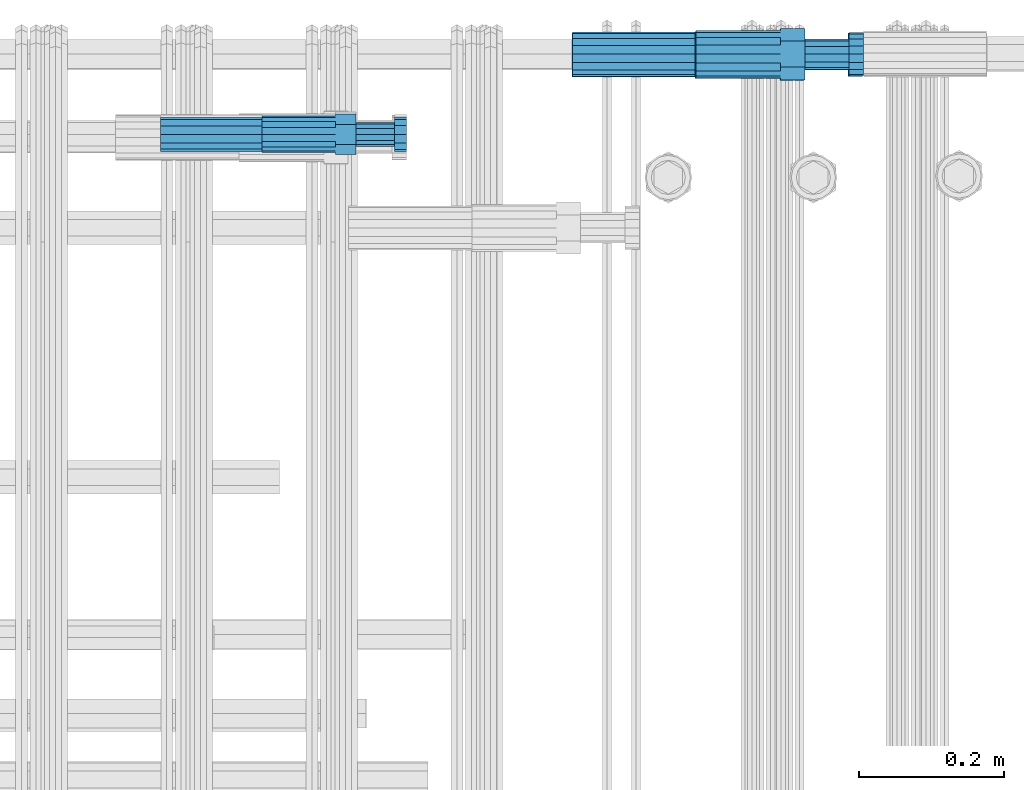
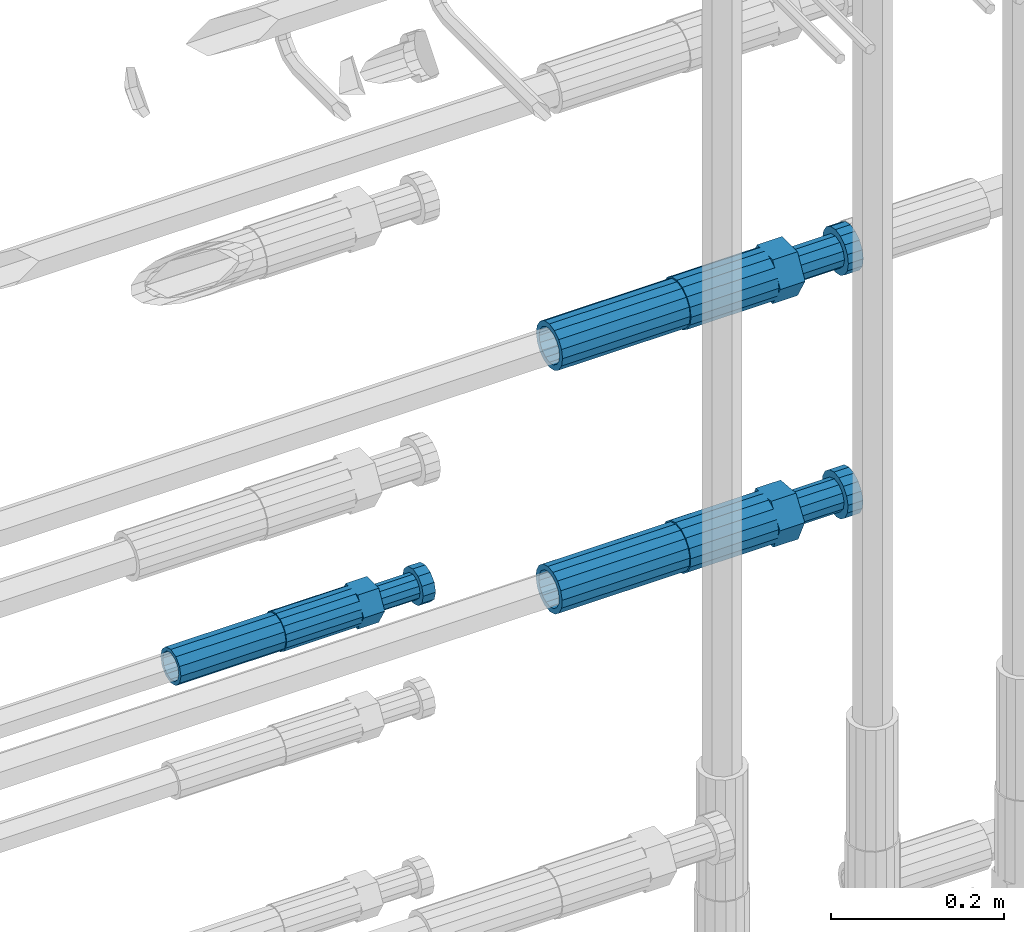
# One storey, part 50 of 177: 6 beams.
"""IFC2X3 building model written with IfcOpenShell, lengths in millimetres."""

from ifc_helpers import new_model, si_unit, frame, origin_with_axes, place, context, subcontext, project, spatial, faceted_brep, material, type_object, element, save


model = new_model("IFC2X3")

# Units and contexts
model_context_1 = context("Model", 3, precision=1e-05, world=origin_with_axes())
model_context_2 = context("Model", 3, precision=1e-05, world=origin_with_axes())
body_context = subcontext(model_context_2, "Body", "Model", "MODEL_VIEW")
ifc_project = project(units=[si_unit("LENGTHUNIT", "METRE", prefix="MILLI"), si_unit("AREAUNIT", "SQUARE_METRE"), si_unit("VOLUMEUNIT", "CUBIC_METRE"), si_unit("MASSUNIT", "GRAM", prefix="KILO"), si_unit("TIMEUNIT", "SECOND"), si_unit("PLANEANGLEUNIT", "RADIAN"), si_unit("SOLIDANGLEUNIT", "STERADIAN"), si_unit("THERMODYNAMICTEMPERATUREUNIT", "DEGREE_CELSIUS"), si_unit("LUMINOUSINTENSITYUNIT", "LUMEN")], contexts=[model_context_1])

# Site, building, storey
site_placement = place(None, origin_with_axes())
site = spatial("IfcSite", under=ifc_project, at=site_placement, CompositionType="ELEMENT")
building_placement = place(site_placement, origin_with_axes())
building = spatial("IfcBuilding", under=site, at=building_placement, Name="Undefined", CompositionType="ELEMENT")
storey_placement = place(building_placement, origin_with_axes())
storey = spatial("IfcBuildingStorey", under=building, at=storey_placement, Name="Undefined", CompositionType="ELEMENT", Elevation=0.0)

# Beams
ifc_material = material(Name="STEEL/S275")
beam_type_1 = type_object("IfcBeamType", PredefinedType="NOTDEFINED")
beam_1_placement = place(storey_placement, frame((2031448.01847313, 6206397.9902193, 19253.0674480899), z_axis=(0.0, -0.0871557420138247, -0.996194698155948), x_axis=(1.0, 0.0, 0.0)))
element("IfcBeam", 1, at=beam_1_placement, inside=storey, type_object=beam_type_1, material=ifc_material, Name="AG40N", context=body_context, shape_type="Brep", body=[
    faceted_brep([(0.0, -23.5000000001164, -9.31322574615479e-10), (0.0, -21.7111690140155, 8.99306066054851), (170.0, -21.7111690140155, 8.99306066054851), (170.0, -23.5, 0.0), (0.0, -16.6170093578839, 16.6170093575493), (170.0, -16.6170093578839, 16.6170093575493), (0.0, -8.99306066057943, 21.7111690137535), (170.0, -8.99306066057943, 21.7111690137535), (0.0, 1.16415321826935e-10, 23.5), (170.0, 0.0, 23.5), (0.0, 8.99306066057943, 21.7111690137535), (170.0, 8.99306066057943, 21.7111690137535), (0.0, 16.6170093578839, 16.6170093575493), (170.0, 16.6170093578839, 16.6170093575493), (0.0, 21.7111690140155, 8.99306066054851), (170.0, 21.7111690140155, 8.99306066054851), (0.0, 23.5000000001164, -9.31322574615479e-10), (170.0, 23.5, 0.0), (0.0, 21.7111690140155, -8.99306066054851), (170.0, 21.7111690140155, -8.99306066054851), (0.0, 16.6170093578839, -16.6170093575493), (170.0, 16.6170093578839, -16.6170093575493), (0.0, 8.99306066057943, -21.7111690137535), (170.0, 8.99306066057943, -21.7111690137535), (0.0, 1.16415321826935e-10, -23.5000000009313), (170.0, 0.0, -23.5), (0.0, -8.99306066057943, -21.7111690137535), (170.0, -8.99306066057943, -21.7111690137535), (0.0, -16.6170093578839, -16.6170093575493), (170.0, -16.6170093578839, -16.6170093575493), (0.0, -21.7111690140155, -8.99306066054851), (170.0, -21.7111690140155, -8.99306066054851), (0.0, -30.5, 0.0), (0.0, -28.1783257415937, -11.6718446873128), (170.0, -28.1783257415937, -11.6718446873128), (170.0, -30.5, 0.0), (0.0, -21.5667568261888, -21.5667568258941), (170.0, -21.5667568261888, -21.5667568258941), (0.0, -11.6718446871346, -28.1783257415518), (170.0, -11.6718446871346, -28.1783257415518), (0.0, 0.0, -30.5), (170.0, 0.0, -30.5), (0.0, 11.6718446871346, -28.1783257415518), (170.0, 11.6718446871346, -28.1783257415518), (0.0, 21.5667568261888, -21.5667568258941), (170.0, 21.5667568261888, -21.5667568258941), (0.0, 28.1783257415937, -11.6718446873128), (170.0, 28.1783257415937, -11.6718446873128), (0.0, 30.5, 0.0), (170.0, 30.5, 0.0), (0.0, 28.1783257415937, 11.6718446873128), (170.0, 28.1783257415937, 11.6718446873128), (0.0, 21.5667568261888, 21.5667568258941), (170.0, 21.5667568261888, 21.5667568258941), (0.0, 11.6718446871346, 28.1783257415518), (170.0, 11.6718446871346, 28.1783257415518), (0.0, 0.0, 30.5), (170.0, 0.0, 30.5), (0.0, -11.6718446871346, 28.1783257415518), (170.0, -11.6718446871346, 28.1783257415518), (0.0, -21.5667568261888, 21.5667568258941), (170.0, -21.5667568261888, 21.5667568258941), (0.0, -28.1783257415937, 11.6718446873128), (170.0, -28.1783257415937, 11.6718446873128)], [[[0, 1, 2, 3]], [[1, 4, 5, 2]], [[4, 6, 7, 5]], [[6, 8, 9, 7]], [[8, 10, 11, 9]], [[10, 12, 13, 11]], [[12, 14, 15, 13]], [[14, 16, 17, 15]], [[16, 18, 19, 17]], [[18, 20, 21, 19]], [[20, 22, 23, 21]], [[22, 24, 25, 23]], [[24, 26, 27, 25]], [[26, 28, 29, 27]], [[28, 30, 31, 29]], [[30, 0, 3, 31]], [[32, 33, 34, 35]], [[33, 36, 37, 34]], [[36, 38, 39, 37]], [[38, 40, 41, 39]], [[40, 42, 43, 41]], [[42, 44, 45, 43]], [[44, 46, 47, 45]], [[46, 48, 49, 47]], [[48, 50, 51, 49]], [[50, 52, 53, 51]], [[52, 54, 55, 53]], [[54, 56, 57, 55]], [[56, 58, 59, 57]], [[58, 60, 61, 59]], [[60, 62, 63, 61]], [[62, 32, 35, 63]], [[37, 39, 41, 43, 45, 47, 49, 51, 53, 55, 57, 59, 61, 63, 35, 34], [5, 7, 9, 11, 13, 15, 17, 19, 21, 23, 25, 27, 29, 31, 3, 2]], [[62, 60, 58, 56, 54, 52, 50, 48, 46, 44, 42, 40, 38, 36, 33, 32], [30, 28, 26, 24, 22, 20, 18, 16, 14, 12, 10, 8, 6, 4, 1, 0]]]),
])
beam_2_placement = place(storey_placement, frame((2031449.01847313, 6206398.98588034, 19594.9868004311), z_axis=(0.0, 0.0, -1.0), x_axis=(1.0, 0.0, 0.0)))
element("IfcBeam", 2, at=beam_2_placement, inside=storey, type_object=beam_type_1, material=ifc_material, Name="AG40N", context=body_context, shape_type="Brep", body=[
    faceted_brep([(0.0, -23.5000000001164, -9.31322574615479e-10), (0.0, -21.7111690140155, 8.99306066054851), (170.0, -21.7111690140155, 8.99306066054851), (170.0, -23.5, 0.0), (0.0, -16.6170093578839, 16.6170093575493), (170.0, -16.6170093578839, 16.6170093575493), (0.0, -8.99306066057943, 21.7111690137535), (170.0, -8.99306066057943, 21.7111690137535), (0.0, 1.16415321826935e-10, 23.5), (170.0, 0.0, 23.5), (0.0, 8.99306066057943, 21.7111690137535), (170.0, 8.99306066057943, 21.7111690137535), (0.0, 16.6170093578839, 16.6170093575493), (170.0, 16.6170093578839, 16.6170093575493), (0.0, 21.7111690140155, 8.99306066054851), (170.0, 21.7111690140155, 8.99306066054851), (0.0, 23.5000000001164, -9.31322574615479e-10), (170.0, 23.5, 0.0), (0.0, 21.7111690140155, -8.99306066054851), (170.0, 21.7111690140155, -8.99306066054851), (0.0, 16.6170093578839, -16.6170093575493), (170.0, 16.6170093578839, -16.6170093575493), (0.0, 8.99306066057943, -21.7111690137535), (170.0, 8.99306066057943, -21.7111690137535), (0.0, 1.16415321826935e-10, -23.5000000009313), (170.0, 0.0, -23.5), (0.0, -8.99306066057943, -21.7111690137535), (170.0, -8.99306066057943, -21.7111690137535), (0.0, -16.6170093578839, -16.6170093575493), (170.0, -16.6170093578839, -16.6170093575493), (0.0, -21.7111690140155, -8.99306066054851), (170.0, -21.7111690140155, -8.99306066054851), (0.0, -30.5, 0.0), (0.0, -28.1783257415937, -11.6718446873128), (170.0, -28.1783257415937, -11.6718446873128), (170.0, -30.5, 0.0), (0.0, -21.5667568261888, -21.5667568258941), (170.0, -21.5667568261888, -21.5667568258941), (0.0, -11.6718446871346, -28.1783257415518), (170.0, -11.6718446871346, -28.1783257415518), (0.0, 0.0, -30.5), (170.0, 0.0, -30.5), (0.0, 11.6718446871346, -28.1783257415518), (170.0, 11.6718446871346, -28.1783257415518), (0.0, 21.5667568261888, -21.5667568258941), (170.0, 21.5667568261888, -21.5667568258941), (0.0, 28.1783257415937, -11.6718446873128), (170.0, 28.1783257415937, -11.6718446873128), (0.0, 30.5, 0.0), (170.0, 30.5, 0.0), (0.0, 28.1783257415937, 11.6718446873128), (170.0, 28.1783257415937, 11.6718446873128), (0.0, 21.5667568261888, 21.5667568258941), (170.0, 21.5667568261888, 21.5667568258941), (0.0, 11.6718446871346, 28.1783257415518), (170.0, 11.6718446871346, 28.1783257415518), (0.0, 0.0, 30.5), (170.0, 0.0, 30.5), (0.0, -11.6718446871346, 28.1783257415518), (170.0, -11.6718446871346, 28.1783257415518), (0.0, -21.5667568261888, 21.5667568258941), (170.0, -21.5667568261888, 21.5667568258941), (0.0, -28.1783257415937, 11.6718446873128), (170.0, -28.1783257415937, 11.6718446873128)], [[[0, 1, 2, 3]], [[1, 4, 5, 2]], [[4, 6, 7, 5]], [[6, 8, 9, 7]], [[8, 10, 11, 9]], [[10, 12, 13, 11]], [[12, 14, 15, 13]], [[14, 16, 17, 15]], [[16, 18, 19, 17]], [[18, 20, 21, 19]], [[20, 22, 23, 21]], [[22, 24, 25, 23]], [[24, 26, 27, 25]], [[26, 28, 29, 27]], [[28, 30, 31, 29]], [[30, 0, 3, 31]], [[32, 33, 34, 35]], [[33, 36, 37, 34]], [[36, 38, 39, 37]], [[38, 40, 41, 39]], [[40, 42, 43, 41]], [[42, 44, 45, 43]], [[44, 46, 47, 45]], [[46, 48, 49, 47]], [[48, 50, 51, 49]], [[50, 52, 53, 51]], [[52, 54, 55, 53]], [[54, 56, 57, 55]], [[56, 58, 59, 57]], [[58, 60, 61, 59]], [[60, 62, 63, 61]], [[62, 32, 35, 63]], [[37, 39, 41, 43, 45, 47, 49, 51, 53, 55, 57, 59, 61, 63, 35, 34], [5, 7, 9, 11, 13, 15, 17, 19, 21, 23, 25, 27, 29, 31, 3, 2]], [[62, 60, 58, 56, 54, 52, 50, 48, 46, 44, 42, 40, 38, 36, 33, 32], [30, 28, 26, 24, 22, 20, 18, 16, 14, 12, 10, 8, 6, 4, 1, 0]]]),
])
beam_type_2 = type_object("IfcBeamType", Name="ROD65", PredefinedType="NOTDEFINED")
beam_3_placement = place(storey_placement, frame((2031618.01847313, 6206397.9902193, 19253.0674480899), z_axis=(0.0, -0.0871557420138247, -0.996194698155948), x_axis=(1.0, 0.0, 0.0)))
element("IfcBeam", 3, at=beam_3_placement, inside=storey, type_object=beam_type_2, material=ifc_material, Name="AGB40", ObjectType="ROD65", context=body_context, shape_type="Brep", body=[
    faceted_brep([(117.0, 8.17543110251427, 30.873805644922), (117.0, 17.8250000001863, 30.873805644922), (117.0, 22.0056958701462, 23.6326279877685), (117.0, 12.4372115517035, 30.0260848065373), (117.0, -17.8250000001863, 30.873805644922), (150.200000000186, -17.8250000001863, 30.873805644922), (150.200000000186, 17.8250000001863, 30.873805644922), (117.0, -8.17543110251427, 30.873805644922), (117.0, -12.4372115517035, 30.0260848065373), (117.0, -22.0056958701462, 23.6326279877685), (117.0, -35.6500000003725, 0.0), (150.200000000186, -35.6500000003725, 0.0), (117.0, -30.8443150008097, 8.32369058486074), (117.0, -32.5, 0.0), (117.0, -30.8443150008097, -8.32369058462791), (117.0, -17.8250000001863, -30.873805644922), (150.200000000186, -17.8250000001863, -30.873805644922), (117.0, -22.0056958701462, -23.6326279877685), (117.0, -12.4372115517035, -30.0260848065373), (117.0, -8.17543110251427, -30.873805644922), (117.0, 17.8250000001863, -30.873805644922), (150.200000000186, 17.8250000001863, -30.873805644922), (117.0, 8.17543110251427, -30.873805644922), (117.0, 22.0056958701462, -23.6326279877685), (117.0, 12.4372115517035, -30.0260848065373), (117.0, 35.6500000003725, 0.0), (150.200000000186, 35.6500000003725, 0.0), (117.0, 30.8443150008097, -8.32369058486074), (117.0, 30.8443150008097, 8.32369058462791), (117.0, 32.5, 0.0), (0.0, -22.9809703892097, 22.9809703885621), (0.0, -30.0260848058388, 12.4372115518636), (117.0, -30.0260848067701, 12.4372115519363), (117.0, -22.9809703882784, 22.9809703885112), (-2.3283064365387e-10, 22.9809703892097, -22.9809703885639), (-4.65661287307739e-10, 30.0260848077014, -12.4372115518672), (117.0, 30.0260848067701, -12.4372115519363), (117.0, 22.9809703882784, -22.9809703885112), (-2.3283064365387e-10, -30.0260848067701, -12.4372115518672), (-2.3283064365387e-10, -22.9809703892097, -22.9809703885621), (117.0, -22.9809703882784, -22.9809703885112), (117.0, -30.0260848067701, -12.4372115519363), (-2.3283064365387e-10, -12.4372115507722, 30.0260848066137), (-2.3283064365387e-10, 9.31322574615479e-10, 32.4999999999982), (-2.3283064365387e-10, 12.4372115526348, 30.0260848066137), (0.0, 22.9809703892097, 22.9809703885621), (-2.3283064365387e-10, 30.0260848077014, 12.4372115518636), (-2.3283064365387e-10, 32.5, 0.0), (-2.3283064365387e-10, 12.4372115526348, -30.0260848066173), (-2.3283064365387e-10, 9.31322574615479e-10, -32.5), (-2.3283064365387e-10, -12.4372115517035, -30.0260848066173), (-4.65661287307739e-10, -32.4999999990687, -1.81898940354586e-12), (117.0, 22.9809703882784, 22.9809703885112), (117.0, 30.0260848067701, 12.4372115519363), (117.0, 0.0, -32.5), (117.0, 0.0, 32.5), (150.200000000186, 10.5, -18.1865334794857), (150.200000000186, 0.0, -21.0), (150.200000000186, -10.5, -18.1865334794857), (150.200000000186, -18.18653347902, -10.5), (150.200000000186, -21.0, 0.0), (150.200000000186, -18.18653347902, 10.5), (150.200000000186, -10.5, 18.1865334794857), (150.200000000186, 0.0, 21.0), (150.200000000186, 10.5, 18.1865334794857), (150.200000000186, 18.18653347902, 10.5), (150.200000000186, 21.0, 0.0), (150.200000000186, 18.18653347902, -10.5), (210.980000000447, -18.18653347902, 10.5), (210.980000000447, -21.0, 0.0), (210.980000000447, -10.5, 18.1865334794857), (210.980000000447, 0.0, 21.0), (210.980000000447, 10.5, 18.1865334794857), (210.980000000447, 18.18653347902, 10.5), (210.980000000447, 21.0, 0.0), (210.980000000447, 18.18653347902, -10.5), (210.980000000447, 10.5, -18.1865334794857), (210.980000000447, 0.0, -21.0), (210.980000000447, -10.5, -18.1865334794857), (210.980000000447, -18.18653347902, -10.5), (211.001368442696, -27.7269937992096, -11.491116326768), (211.003082550167, -21.2238094303757, -21.223815418547), (231.002518367059, -21.2131944671273, -21.2132004550658), (231.000804259587, -27.7163788359612, -11.4805013632867), (211.001368440451, -11.4911085031927, -27.7269970395137), (231.000804257343, -11.4804935399443, -27.7163820760325), (210.996487071217, -0.0106065049767494, -30.0106107392348), (230.995922888109, 8.45827162265778e-06, -29.9999957757536), (210.989181586672, 11.46989420522, -27.7269970329944), (230.988617403564, 11.4805091684684, -27.7163820695132), (210.980564180623, 21.2025914648548, -21.2238154064398), (230.979999997515, 21.2132064281031, -21.2132004429586), (210.971946775022, 27.7057703435421, -11.4911163107026), (230.971382591913, 27.7163853067905, -11.4805013472214), (210.96464129175, 29.9893808094785, -0.0106149562634528), (230.964077108642, 29.9999957727268, 7.21774995326996e-09), (210.959759924415, 27.7057638689876, 11.4698863970116), (230.959195741307, 27.7163788322359, 11.4805013604928), (210.958045816944, 21.2025795001537, 21.2025854887906), (230.957481633835, 21.213194463402, 21.2132004522718), (210.95975992666, 11.4698785729706, 27.7057671097573), (230.959195743551, 11.480493536219, 27.7163820732385), (210.964641295894, -0.010623425245285, 29.9893808094785), (230.964077112785, -8.46199691295624e-06, 29.9999957729597), (210.971946780439, -11.4911241354421, 27.705767103238), (230.97138259733, -11.4805091721937, 27.7163820667192), (210.980564186488, -21.2238213950768, 21.2025854766835), (230.980000003379, -21.2132064318284, 21.2132004401647), (210.989181592089, -27.7270002737641, 11.4698863809463), (230.988617408981, -27.7163853105158, 11.4805013444275), (210.996487075361, -30.0106107397005, -0.0106149734929204), (230.995922892253, -29.9999957764521, -1.00117176771164e-08)], [[[0, 1, 2, 3]], [[4, 5, 6, 1, 0, 7]], [[4, 7, 8, 9]], [[10, 11, 5, 4, 9, 12]], [[10, 12, 13, 14]], [[15, 16, 11, 10, 14, 17]], [[15, 17, 18, 19]], [[20, 21, 16, 15, 19, 22]], [[23, 20, 22, 24]], [[25, 26, 21, 20, 23, 27]], [[28, 25, 27, 29]], [[30, 31, 32, 33]], [[34, 35, 36, 37]], [[38, 39, 40, 41]], [[31, 30, 42, 43, 44, 45, 46, 47, 35, 34, 48, 49, 50, 39, 38, 51]], [[46, 45, 52, 53]], [[29, 47, 46, 53, 28]], [[27, 36, 35, 47, 29]], [[23, 37, 36, 27]], [[24, 48, 34, 37, 23]], [[22, 54, 49, 48, 24]], [[19, 54, 22]], [[18, 50, 49, 54, 19]], [[17, 40, 39, 50, 18]], [[14, 41, 40, 17]], [[13, 51, 38, 41, 14]], [[12, 32, 31, 51, 13]], [[9, 33, 32, 12]], [[8, 42, 30, 33, 9]], [[7, 55, 43, 42, 8]], [[0, 55, 7]], [[3, 44, 43, 55, 0]], [[2, 52, 45, 44, 3]], [[28, 53, 52, 2]], [[1, 6, 26, 25, 28, 2]], [[5, 11, 16, 21, 26, 6], [56, 57, 58, 59, 60, 61, 62, 63, 64, 65, 66, 67]], [[68, 61, 60, 69]], [[70, 62, 61, 68]], [[71, 63, 62, 70]], [[72, 64, 63, 71]], [[73, 65, 64, 72]], [[74, 66, 65, 73]], [[75, 67, 66, 74]], [[76, 56, 67, 75]], [[77, 57, 56, 76]], [[78, 58, 57, 77]], [[79, 59, 58, 78]], [[69, 60, 59, 79]], [[80, 81, 82, 83]], [[81, 84, 85, 82]], [[84, 86, 87, 85]], [[86, 88, 89, 87]], [[88, 90, 91, 89]], [[90, 92, 93, 91]], [[92, 94, 95, 93]], [[94, 96, 97, 95]], [[96, 98, 99, 97]], [[98, 100, 101, 99]], [[100, 102, 103, 101]], [[102, 104, 105, 103]], [[104, 106, 107, 105]], [[106, 108, 109, 107]], [[108, 110, 111, 109]], [[82, 85, 87, 89, 91, 93, 95, 97, 99, 101, 103, 105, 107, 109, 111, 83]], [[110, 80, 83, 111]], [[108, 106, 104, 102, 100, 98, 96, 94, 92, 90, 88, 86, 84, 81, 80, 110], [75, 74, 73, 72, 71, 70, 68, 69, 79, 78, 77, 76]]]),
])
beam_4_placement = place(storey_placement, frame((2031619.01847313, 6206398.98588034, 19594.9868004311), z_axis=(0.0, 0.0, -1.0), x_axis=(1.0, 0.0, 0.0)))
element("IfcBeam", 4, at=beam_4_placement, inside=storey, type_object=beam_type_2, material=ifc_material, Name="AGB40", ObjectType="ROD65", context=body_context, shape_type="Brep", body=[
    faceted_brep([(117.0, 8.17543110251427, 30.873805644922), (117.0, 17.8250000001863, 30.873805644922), (117.0, 22.0056958701462, 23.6326279877685), (117.0, 12.4372115517035, 30.0260848065373), (117.0, -17.8250000001863, 30.873805644922), (150.200000000186, -17.8250000001863, 30.873805644922), (150.200000000186, 17.8250000001863, 30.873805644922), (117.0, -8.17543110251427, 30.873805644922), (117.0, -12.4372115517035, 30.0260848065373), (117.0, -22.0056958701462, 23.6326279877685), (117.0, -35.6500000003725, 0.0), (150.200000000186, -35.6500000003725, 0.0), (117.0, -30.8443150008097, 8.32369058486074), (117.0, -32.5, 0.0), (117.0, -30.8443150008097, -8.32369058462791), (117.0, -17.8250000001863, -30.873805644922), (150.200000000186, -17.8250000001863, -30.873805644922), (117.0, -22.0056958701462, -23.6326279877685), (117.0, -12.4372115517035, -30.0260848065373), (117.0, -8.17543110251427, -30.873805644922), (117.0, 17.8250000001863, -30.873805644922), (150.200000000186, 17.8250000001863, -30.873805644922), (117.0, 8.17543110251427, -30.873805644922), (117.0, 22.0056958701462, -23.6326279877685), (117.0, 12.4372115517035, -30.0260848065373), (117.0, 35.6500000003725, 0.0), (150.200000000186, 35.6500000003725, 0.0), (117.0, 30.8443150008097, -8.32369058486074), (117.0, 30.8443150008097, 8.32369058462791), (117.0, 32.5, 0.0), (0.0, -22.9809703892097, 22.9809703885621), (0.0, -30.0260848058388, 12.4372115518636), (117.0, -30.0260848067701, 12.4372115519363), (117.0, -22.9809703882784, 22.9809703885112), (-2.3283064365387e-10, 22.9809703892097, -22.9809703885639), (-4.65661287307739e-10, 30.0260848077014, -12.4372115518672), (117.0, 30.0260848067701, -12.4372115519363), (117.0, 22.9809703882784, -22.9809703885112), (-2.3283064365387e-10, -30.0260848067701, -12.4372115518672), (-2.3283064365387e-10, -22.9809703892097, -22.9809703885621), (117.0, -22.9809703882784, -22.9809703885112), (117.0, -30.0260848067701, -12.4372115519363), (-2.3283064365387e-10, -12.4372115507722, 30.0260848066137), (-2.3283064365387e-10, 9.31322574615479e-10, 32.4999999999982), (-2.3283064365387e-10, 12.4372115526348, 30.0260848066137), (0.0, 22.9809703892097, 22.9809703885621), (-2.3283064365387e-10, 30.0260848077014, 12.4372115518636), (-2.3283064365387e-10, 32.5, 0.0), (-2.3283064365387e-10, 12.4372115526348, -30.0260848066173), (-2.3283064365387e-10, 9.31322574615479e-10, -32.5), (-2.3283064365387e-10, -12.4372115517035, -30.0260848066173), (-4.65661287307739e-10, -32.4999999990687, -1.81898940354586e-12), (117.0, 22.9809703882784, 22.9809703885112), (117.0, 30.0260848067701, 12.4372115519363), (117.0, 0.0, -32.5), (117.0, 0.0, 32.5), (150.200000000186, 10.5, -18.1865334794857), (150.200000000186, 0.0, -21.0), (150.200000000186, -10.5, -18.1865334794857), (150.200000000186, -18.18653347902, -10.5), (150.200000000186, -21.0, 0.0), (150.200000000186, -18.18653347902, 10.5), (150.200000000186, -10.5, 18.1865334794857), (150.200000000186, 0.0, 21.0), (150.200000000186, 10.5, 18.1865334794857), (150.200000000186, 18.18653347902, 10.5), (150.200000000186, 21.0, 0.0), (150.200000000186, 18.18653347902, -10.5), (210.980000000447, -18.18653347902, 10.5), (210.980000000447, -21.0, 0.0), (210.980000000447, -10.5, 18.1865334794857), (210.980000000447, 0.0, 21.0), (210.980000000447, 10.5, 18.1865334794857), (210.980000000447, 18.18653347902, 10.5), (210.980000000447, 21.0, 0.0), (210.980000000447, 18.18653347902, -10.5), (210.980000000447, 10.5, -18.1865334794857), (210.980000000447, 0.0, -21.0), (210.980000000447, -10.5, -18.1865334794857), (210.980000000447, -18.18653347902, -10.5), (211.001368442696, -27.7269937992096, -11.491116326768), (211.003082550167, -21.2238094303757, -21.223815418547), (231.002518367059, -21.2131944671273, -21.2132004550658), (231.000804259587, -27.7163788359612, -11.4805013632867), (211.001368440451, -11.4911085031927, -27.7269970395137), (231.000804257343, -11.4804935399443, -27.7163820760325), (210.996487071217, -0.0106065049767494, -30.0106107392348), (230.995922888109, 8.45827162265778e-06, -29.9999957757536), (210.989181586672, 11.46989420522, -27.7269970329944), (230.988617403564, 11.4805091684684, -27.7163820695132), (210.980564180623, 21.2025914648548, -21.2238154064398), (230.979999997515, 21.2132064281031, -21.2132004429586), (210.971946775022, 27.7057703435421, -11.4911163107026), (230.971382591913, 27.7163853067905, -11.4805013472214), (210.96464129175, 29.9893808094785, -0.0106149562634528), (230.964077108642, 29.9999957727268, 7.21774995326996e-09), (210.959759924415, 27.7057638689876, 11.4698863970116), (230.959195741307, 27.7163788322359, 11.4805013604928), (210.958045816944, 21.2025795001537, 21.2025854887906), (230.957481633835, 21.213194463402, 21.2132004522718), (210.95975992666, 11.4698785729706, 27.7057671097573), (230.959195743551, 11.480493536219, 27.7163820732385), (210.964641295894, -0.010623425245285, 29.9893808094785), (230.964077112785, -8.46199691295624e-06, 29.9999957729597), (210.971946780439, -11.4911241354421, 27.705767103238), (230.97138259733, -11.4805091721937, 27.7163820667192), (210.980564186488, -21.2238213950768, 21.2025854766835), (230.980000003379, -21.2132064318284, 21.2132004401647), (210.989181592089, -27.7270002737641, 11.4698863809463), (230.988617408981, -27.7163853105158, 11.4805013444275), (210.996487075361, -30.0106107397005, -0.0106149734929204), (230.995922892253, -29.9999957764521, -1.00117176771164e-08)], [[[0, 1, 2, 3]], [[4, 5, 6, 1, 0, 7]], [[4, 7, 8, 9]], [[10, 11, 5, 4, 9, 12]], [[10, 12, 13, 14]], [[15, 16, 11, 10, 14, 17]], [[15, 17, 18, 19]], [[20, 21, 16, 15, 19, 22]], [[23, 20, 22, 24]], [[25, 26, 21, 20, 23, 27]], [[28, 25, 27, 29]], [[30, 31, 32, 33]], [[34, 35, 36, 37]], [[38, 39, 40, 41]], [[31, 30, 42, 43, 44, 45, 46, 47, 35, 34, 48, 49, 50, 39, 38, 51]], [[46, 45, 52, 53]], [[29, 47, 46, 53, 28]], [[27, 36, 35, 47, 29]], [[23, 37, 36, 27]], [[24, 48, 34, 37, 23]], [[22, 54, 49, 48, 24]], [[19, 54, 22]], [[18, 50, 49, 54, 19]], [[17, 40, 39, 50, 18]], [[14, 41, 40, 17]], [[13, 51, 38, 41, 14]], [[12, 32, 31, 51, 13]], [[9, 33, 32, 12]], [[8, 42, 30, 33, 9]], [[7, 55, 43, 42, 8]], [[0, 55, 7]], [[3, 44, 43, 55, 0]], [[2, 52, 45, 44, 3]], [[28, 53, 52, 2]], [[1, 6, 26, 25, 28, 2]], [[5, 11, 16, 21, 26, 6], [56, 57, 58, 59, 60, 61, 62, 63, 64, 65, 66, 67]], [[68, 61, 60, 69]], [[70, 62, 61, 68]], [[71, 63, 62, 70]], [[72, 64, 63, 71]], [[73, 65, 64, 72]], [[74, 66, 65, 73]], [[75, 67, 66, 74]], [[76, 56, 67, 75]], [[77, 57, 56, 76]], [[78, 58, 57, 77]], [[79, 59, 58, 78]], [[69, 60, 59, 79]], [[80, 81, 82, 83]], [[81, 84, 85, 82]], [[84, 86, 87, 85]], [[86, 88, 89, 87]], [[88, 90, 91, 89]], [[90, 92, 93, 91]], [[92, 94, 95, 93]], [[94, 96, 97, 95]], [[96, 98, 99, 97]], [[98, 100, 101, 99]], [[100, 102, 103, 101]], [[102, 104, 105, 103]], [[104, 106, 107, 105]], [[106, 108, 109, 107]], [[108, 110, 111, 109]], [[82, 85, 87, 89, 91, 93, 95, 97, 99, 101, 103, 105, 107, 109, 111, 83]], [[110, 80, 83, 111]], [[108, 106, 104, 102, 100, 98, 96, 94, 92, 90, 88, 86, 84, 81, 80, 110], [75, 74, 73, 72, 71, 70, 68, 69, 79, 78, 77, 76]]]),
])
beam_type_3 = type_object("IfcBeamType", PredefinedType="NOTDEFINED")
beam_5_placement = place(storey_placement, frame((2030880.99847313, 6206288.48588035, 19409.4868004347), z_axis=(0.0, 0.0, -1.0), x_axis=(1.0, 0.0, 0.0)))
element("IfcBeam", 5, at=beam_5_placement, inside=storey, type_object=beam_type_3, material=ifc_material, Name="AG32N", context=body_context, shape_type="Brep", body=[
    faceted_brep([(0.0, -18.4999999998836, -9.31322574615479e-10), (7.0839612702856e-11, -16.0214699700121, 9.25), (140.0, -16.0214699698845, 9.24999999906868), (140.0, -18.4999999998836, -9.31322574615479e-10), (0.0, -9.24999999988358, 16.0214699683711), (140.0, -9.24999999988358, 16.0214699683711), (9.69157554209232e-11, 0.0, 18.5), (140.0, -1.16415321826935e-10, 18.4999999981374), (0.0, 9.24999999988358, 16.0214699683711), (140.0, 9.24999999988358, 16.0214699683711), (2.60761427180671e-11, 16.0214699700121, 9.24999999999999), (140.0, 16.0214699698845, 9.24999999906868), (0.0, 18.5000000001164, -9.31322574615479e-10), (140.0, 18.5000000001164, -9.31322574615479e-10), (-7.0839612702856e-11, 16.0214699700121, -9.25000000000001), (140.0, 16.0214699701173, -9.25000000093132), (0.0, 9.25000000011642, -16.0214699711651), (140.0, 9.25000000011642, -16.0214699711651), (-9.69157554209232e-11, -7.18869408444789e-15, -18.5), (140.0, -1.16415321826935e-10, -18.5000000009313), (0.0, -9.25000000011642, -16.0214699702337), (140.0, -9.25000000011642, -16.0214699702337), (-2.60761427180672e-11, -16.0214699700121, -9.25), (140.0, -16.0214699701173, -9.25000000093132), (0.0, -23.5000000001164, -9.31322574615479e-10), (0.0, -20.3515969890868, -11.75), (140.0, -20.3515969890868, -11.75), (140.0, -23.5000000001164, -9.31322574615479e-10), (0.0, -11.7500000001164, -20.3515969896689), (140.0, -11.7500000001164, -20.3515969896689), (0.0, 1.16415321826935e-10, -23.5000000009313), (140.0, 1.16415321826935e-10, -23.5000000009313), (0.0, 11.7500000001164, -20.3515969896689), (140.0, 11.7500000001164, -20.3515969896689), (0.0, 20.3515969890868, -11.7500000009313), (140.0, 20.3515969890868, -11.7500000009313), (0.0, 23.5000000001164, -9.31322574615479e-10), (140.0, 23.5000000001164, -9.31322574615479e-10), (0.0, 20.351596988854, 11.7499999990687), (140.0, 20.351596988854, 11.7499999990687), (0.0, 11.7499999998836, 20.3515969878063), (140.0, 11.7499999998836, 20.3515969878063), (0.0, 1.16415321826935e-10, 23.5), (140.0, 1.16415321826935e-10, 23.5), (0.0, -11.7499999998836, 20.3515969887376), (140.0, -11.7499999998836, 20.3515969887376), (0.0, -20.3515969893197, 11.7499999981374), (140.0, -20.3515969893197, 11.7499999981374)], [[[0, 1, 2, 3]], [[1, 4, 5, 2]], [[4, 6, 7, 5]], [[6, 8, 9, 7]], [[8, 10, 11, 9]], [[10, 12, 13, 11]], [[12, 14, 15, 13]], [[14, 16, 17, 15]], [[16, 18, 19, 17]], [[18, 20, 21, 19]], [[20, 22, 23, 21]], [[22, 0, 3, 23]], [[24, 25, 26, 27]], [[25, 28, 29, 26]], [[28, 30, 31, 29]], [[30, 32, 33, 31]], [[32, 34, 35, 33]], [[34, 36, 37, 35]], [[36, 38, 39, 37]], [[38, 40, 41, 39]], [[40, 42, 43, 41]], [[42, 44, 45, 43]], [[44, 46, 47, 45]], [[46, 24, 27, 47]], [[29, 31, 33, 35, 37, 39, 41, 43, 45, 47, 27, 26], [5, 7, 9, 11, 13, 15, 17, 19, 21, 23, 3, 2]], [[46, 44, 42, 40, 38, 36, 34, 32, 30, 28, 25, 24], [22, 20, 18, 16, 14, 12, 10, 8, 6, 4, 1, 0]]]),
])
beam_type_4 = type_object("IfcBeamType", Name="ROD50", PredefinedType="NOTDEFINED")
beam_6_placement = place(storey_placement, frame((2031020.99847313, 6206288.48588035, 19409.4868004347), z_axis=(0.0, 0.0, -1.0), x_axis=(1.0, 0.0, 0.0)))
element("IfcBeam", 6, at=beam_6_placement, inside=storey, type_object=beam_type_4, material=ifc_material, Name="AGB32", ObjectType="ROD50", context=body_context, shape_type="Brep", body=[
    faceted_brep([(129.100000000559, -13.8425000002608, 23.9759132992476), (129.100000000559, -27.6850000005215, -4.65661287307739e-09), (129.100000000559, -13.8424999993294, -23.9759133085608), (129.100000000559, 13.8425000002608, -23.975913308328), (129.100000000559, 27.6849999995902, -4.42378222942352e-09), (129.100000000559, 13.8424999993294, 23.9759132992476), (101.0, -13.8424999993294, -23.9759133085608), (101.0, -27.6850000005215, -4.65661287307739e-09), (101.0, -23.5887256413698, -7.09495531534776), (101.0, -17.528511938639, -17.5915533546358), (101.0, -9.56708580814302, -23.0969883131329), (101.0, -5.14843146782368, -23.975913308328), (101.0, 13.8425000002608, -23.975913308328), (101.0, 5.14843147061765, -23.975913308328), (101.0, 9.56708581000566, -23.0969883129001), (101.0, 17.5285119377077, -17.5915533537045), (101.0, 27.6849999995902, -4.42378222942352e-09), (101.0, 23.5887256432325, -7.09495531162247), (101.0, 25.0000000009313, -2.3283064365387e-10), (101.0, 23.5887256460264, 7.09495529648848), (101.0, 13.8424999993294, 23.9759132992476), (101.0, 17.5285119339824, 17.5915533511434), (101.0, 5.14843151345849, 23.9759132992476), (101.0, 9.56708581000566, 23.0969883126672), (101.0, -13.8425000002608, 23.9759132992476), (101.0, -5.14843151252717, 23.9759132990148), (101.0, -17.5285119339824, 17.5915533518419), (101.0, -9.56708580814302, 23.0969883126672), (101.0, -23.5887256441638, 7.09495530254208), (101.0, -24.9999999990687, -2.3283064365387e-10), (101.0, -23.0969883119687, 9.56708580884151), (0.0, -23.0969883129001, 9.56708580912709), (0.0, -25.0, 0.0), (0.0, -17.6776695298031, 17.677669529663), (0.0, -9.56708580907434, 23.0969883127818), (101.0, 9.31322574615479e-10, 24.9999999997672), (0.0, 0.0, 25.0), (0.0, 9.56708580907434, 23.0969883127818), (0.0, 17.6776695298031, 17.677669529663), (0.0, 23.0969883129001, 9.56708580912709), (101.0, 23.0969883138314, 9.56708580884151), (0.0, 25.0, 0.0), (101.0, 23.0969883138314, -9.56708580930717), (0.0, 23.0969883129001, -9.56708580912709), (0.0, 17.6776695298031, -17.677669529663), (0.0, 9.56708580907434, -23.0969883127818), (101.0, 0.0, -25.0), (0.0, 0.0, -25.0), (0.0, -9.56708580907434, -23.0969883127818), (0.0, -17.6776695298031, -17.677669529663), (0.0, -23.0969883129001, -9.56708580912709), (101.0, -23.0969883119687, -9.56708580930717), (129.5, -14.2894191620871, 8.24999999511056), (129.5, -8.25, 14.2894191578962), (129.5, 0.0, 16.4999999953434), (129.5, 8.25, 14.2894191576634), (129.5, 14.2894191620871, 8.24999999557622), (129.5, 16.5, -4.65661287307739e-09), (129.5, 14.2894191620871, -8.25000000465661), (129.5, 8.25, -14.2894191672094), (129.5, 0.0, -16.5000000046566), (129.5, -8.25000000093132, -14.2894191669766), (129.5, -14.2894191630185, -8.25000000465661), (129.5, -16.5, -4.65661287307739e-09), (182.500000000466, -14.2894191620871, 8.24999999511056), (182.500000000466, -16.5, -4.65661287307739e-09), (182.500000000466, -8.25, 14.2894191578962), (182.500000000466, 0.0, 16.4999999953434), (182.500000000466, 8.25, 14.2894191576634), (182.500000000466, 14.2894191620871, 8.24999999557622), (182.500000000466, 16.5, -4.65661287307739e-09), (182.500000000466, 14.2894191620871, -8.25000000465661), (182.500000000466, 8.25, -14.2894191672094), (182.500000000466, 0.0, -16.5000000046566), (182.500000000466, -8.25000000093132, -14.2894191669766), (182.500000000466, -14.2894191630185, -8.25000000465661), (182.5, -20.7846096921712, -12.0000000044238), (182.5, -12.0, -20.7846096954308), (199.0, -12.0, -20.7846096954308), (199.0, -20.7846096921712, -12.0000000044238), (182.5, -9.31322574615479e-10, -24.0000000044238), (199.0, -9.31322574615479e-10, -24.0000000044238), (182.5, 12.0, -20.7846096956637), (199.0, 12.0, -20.7846096956637), (182.5, 20.7846096912399, -12.0000000046566), (199.0, 20.7846096912399, -12.0000000046566), (182.5, 24.0, -4.65661287307739e-09), (199.0, 24.0, -4.65661287307739e-09), (182.5, 20.7846096912399, 11.9999999953434), (199.0, 20.7846096912399, 11.9999999953434), (182.5, 12.0, 20.7846096863504), (199.0, 12.0, 20.7846096863504), (182.5, -9.31322574615479e-10, 23.9999999953434), (199.0, -9.31322574615479e-10, 23.9999999953434), (182.5, -12.0000000009313, 20.7846096861176), (199.0, -12.0000000009313, 20.7846096861176), (182.5, -20.7846096912399, 11.9999999955762), (199.0, -20.7846096912399, 11.9999999955762), (182.5, -24.0, -4.65661287307739e-09), (199.0, -24.0, -4.65661287307739e-09)], [[[0, 1, 2, 3, 4, 5]], [[6, 2, 1, 7, 8, 9]], [[6, 9, 10, 11]], [[12, 3, 2, 6, 11, 13]], [[12, 13, 14, 15]], [[16, 4, 3, 12, 15, 17]], [[16, 17, 18, 19]], [[20, 5, 4, 16, 19, 21]], [[22, 20, 21, 23]], [[24, 0, 5, 20, 22, 25]], [[26, 24, 25, 27]], [[7, 1, 0, 24, 26, 28]], [[7, 28, 29, 8]], [[28, 30, 31, 32, 29]], [[26, 30, 28]], [[33, 31, 30, 26]], [[27, 34, 33, 26]], [[25, 35, 36, 34, 27]], [[22, 35, 25]], [[23, 37, 36, 35, 22]], [[21, 38, 37, 23]], [[39, 38, 21, 40]], [[19, 40, 21]], [[18, 41, 39, 40, 19]], [[17, 42, 43, 41, 18]], [[15, 42, 17]], [[44, 43, 42, 15]], [[14, 45, 44, 15]], [[13, 46, 47, 45, 14]], [[11, 46, 13]], [[10, 48, 47, 46, 11]], [[9, 49, 48, 10]], [[50, 49, 9, 51]], [[8, 51, 9]], [[29, 32, 50, 51, 8]], [[31, 33, 34, 36, 37, 38, 39, 41, 43, 44, 45, 47, 48, 49, 50, 32]], [[52, 53, 54, 55, 56, 57, 58, 59, 60, 61, 62, 63]], [[64, 52, 63, 65]], [[66, 53, 52, 64]], [[67, 54, 53, 66]], [[68, 55, 54, 67]], [[69, 56, 55, 68]], [[70, 57, 56, 69]], [[71, 58, 57, 70]], [[72, 59, 58, 71]], [[73, 60, 59, 72]], [[74, 61, 60, 73]], [[75, 62, 61, 74]], [[65, 63, 62, 75]], [[76, 77, 78, 79]], [[77, 80, 81, 78]], [[80, 82, 83, 81]], [[82, 84, 85, 83]], [[84, 86, 87, 85]], [[86, 88, 89, 87]], [[88, 90, 91, 89]], [[90, 92, 93, 91]], [[92, 94, 95, 93]], [[94, 96, 97, 95]], [[96, 98, 99, 97]], [[78, 81, 83, 85, 87, 89, 91, 93, 95, 97, 99, 79]], [[98, 76, 79, 99]], [[96, 94, 92, 90, 88, 86, 84, 82, 80, 77, 76, 98], [68, 67, 66, 64, 65, 75, 74, 73, 72, 71, 70, 69]]]),
])

save(model, "model.ifc")
